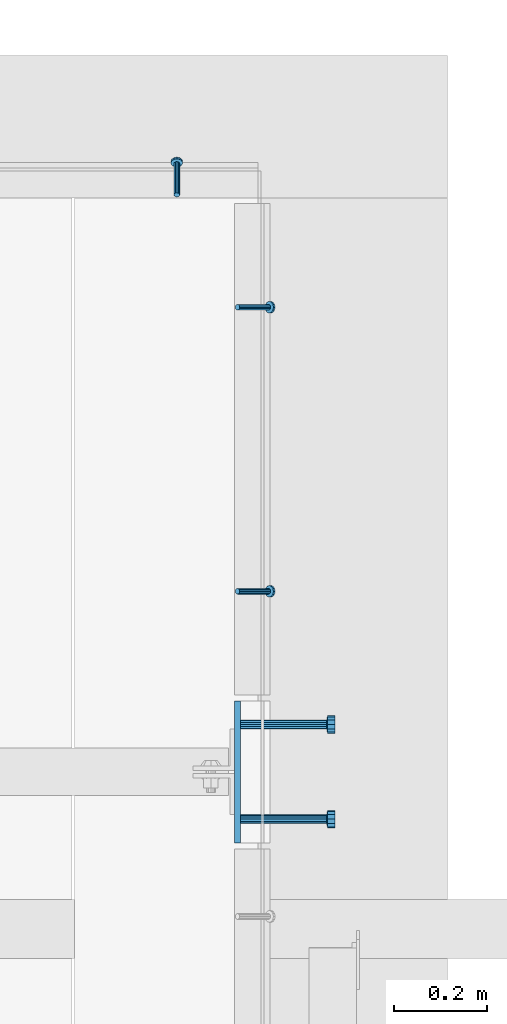
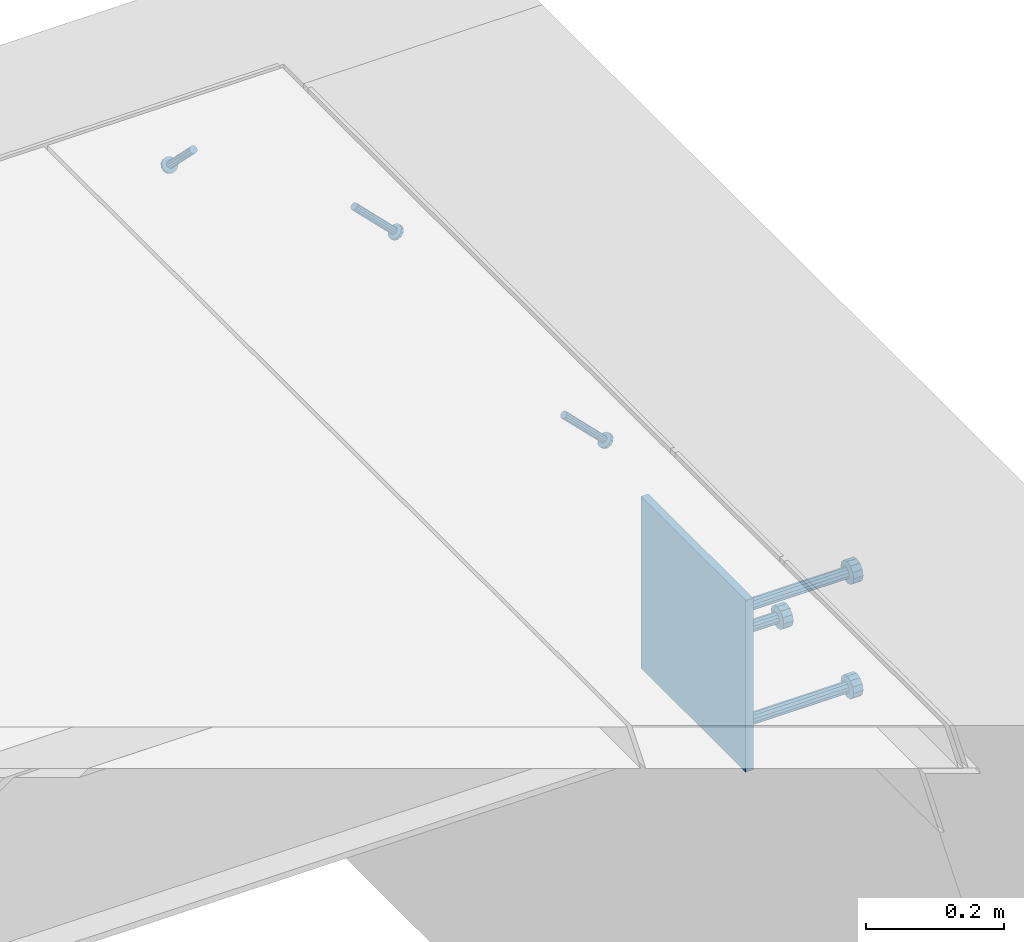
# One storey, part 2153 of 3843: 4 beams, 3 members, 3 elements without a shape of their own.
"""IFC2X3 building model written with IfcOpenShell, lengths in millimetres."""

from ifc_helpers import new_model, si_unit, frame, origin_with_axes, place, context, subcontext, project, spatial, faceted_brep, material, type_object, element, aggregate, save


model = new_model("IFC2X3")

# Units and contexts
model_context = context("Model", 3, precision=1e-05, world=origin_with_axes())
body_context = subcontext(model_context, "Body", "Model", "MODEL_VIEW")
ifc_project = project(units=[si_unit("LENGTHUNIT", "METRE", prefix="MILLI"), si_unit("AREAUNIT", "SQUARE_METRE"), si_unit("VOLUMEUNIT", "CUBIC_METRE"), si_unit("MASSUNIT", "GRAM", prefix="KILO"), si_unit("TIMEUNIT", "SECOND"), si_unit("PLANEANGLEUNIT", "RADIAN"), si_unit("SOLIDANGLEUNIT", "STERADIAN"), si_unit("THERMODYNAMICTEMPERATUREUNIT", "DEGREE_CELSIUS"), si_unit("LUMINOUSINTENSITYUNIT", "LUMEN")], contexts=[model_context])

# Site, building, storey
site_placement = place(None, origin_with_axes())
site = spatial("IfcSite", under=ifc_project, at=site_placement, CompositionType="ELEMENT")
building_placement = place(site_placement, origin_with_axes())
building = spatial("IfcBuilding", under=site, at=building_placement, Name="Undefined", CompositionType="ELEMENT")
storey_placement = place(building_placement, origin_with_axes())
storey = spatial("IfcBuildingStorey", under=building, at=storey_placement, Name="Undefined", CompositionType="ELEMENT", Elevation=0.0)

# Assembly, members
assembly_1_placement = place(storey_placement, origin_with_axes())
assembly_1 = element("IfcElementAssembly", 1, at=assembly_1_placement, inside=storey, Name="ANGLE", AssemblyPlace="NOTDEFINED", PredefinedType="RIGID_FRAME")
ifc_material_1 = material(Name="STEEL/A108")
member_type = type_object("IfcMemberType", PredefinedType="NOTDEFINED")
member_1_placement = place(assembly_1_placement, frame((65849.4999695419, 18456.2751644599, 30422.8500045777), z_axis=(0.0, 1.0, 0.0), x_axis=(0.707106781186548, 0.0, -0.707106781186548)))
member_1 = element("IfcMember", 2, at=member_1_placement, type_object=member_type, material=ifc_material_1, Name="HEADED STUD ANCHOR", context=body_context, shape_type="Brep", body=[
    faceted_brep([(7.27595761418343e-12, -3.18000006675175, 5.5), (0.0, -5.49999999998363, 3.1800000667572), (94.4879985803855, -5.50000000011278, 3.1800000667572), (94.4879985803782, -3.18000006687362, 5.5), (0.0, -6.3499999046162, 0.0), (94.4879985803855, -6.34999990474535, 0.0), (0.0, -5.49999999998363, -3.1800000667572), (94.4879985803855, -5.50000000011278, -3.1800000667572), (7.27595761418343e-12, -3.18000006675175, -5.5), (94.4879985803782, -3.18000006687362, -5.5), (7.27595761418343e-12, -1.81898940354586e-12, -6.34999990463257), (94.4879985803782, -1.20053300634027e-10, -6.34999990463257), (0.0, 3.18000006675175, -5.5), (94.4879985803709, 3.18000006663351, -5.5), (7.27595761418343e-12, 5.49999999998363, -3.1800000667572), (94.4879985803709, 5.49999999987267, -3.1800000667572), (7.27595761418343e-12, 6.3499999046162, 0.0), (94.4879985803673, 6.34999990450706, 0.0), (7.27595761418343e-12, 5.49999999998363, 3.1800000667572), (94.4879985803709, 5.49999999987267, 3.1800000667572), (0.0, 3.18000006675175, 5.5), (94.4879985803709, 3.18000006663351, 5.5), (7.27595761418343e-12, -1.81898940354586e-12, 6.34999990463257), (94.4879985803782, -1.20053300634027e-10, 6.34999990463257), (96.5199985498621, -10.9899997712273, 6.34999990463257), (96.5199985498548, -6.34000015270249, 10.9899997711182), (96.5199985498621, -12.6999998093743, 0.0), (96.5199985498621, -10.9899997712273, -6.34999990463257), (96.5199985498548, -6.34000015270249, -10.9899997711182), (96.5199985498475, -1.21872290037572e-10, -12.6899995803833), (96.5199985498402, 6.34000015245874, -10.9899997711182), (96.519998549833, 10.9899997709817, -6.34999990463257), (96.519998549833, 12.6999998091305, 0.0), (96.519998549833, 10.9899997709817, 6.34999990463257), (96.5199985498402, 6.34000015245874, 10.9899997711182), (96.5199985498475, -1.21872290037572e-10, 12.6899995803833), (101.599998473539, -10.9899997712328, 6.34999990463257), (101.599998473532, -6.34000015270976, 10.9899997711182), (101.599998473539, -12.6999998093797, 0.0), (101.599998473539, -10.9899997712328, -6.34999990463257), (101.599998473532, -6.34000015270976, -10.9899997711182), (101.599998473524, -1.29148247651756e-10, -12.6899995803833), (101.599998473517, 6.34000015245329, -10.9899997711182), (101.59999847351, 10.9899997709763, -6.34999990463257), (101.599998473503, 12.6999998091196, 0.0), (101.59999847351, 10.9899997709763, 6.34999990463257), (101.599998473517, 6.34000015245329, 10.9899997711182), (101.599998473524, -1.29148247651756e-10, 12.6899995803833)], [[[0, 1, 2, 3]], [[1, 4, 5, 2]], [[4, 6, 7, 5]], [[6, 8, 9, 7]], [[8, 10, 11, 9]], [[10, 12, 13, 11]], [[12, 14, 15, 13]], [[14, 16, 17, 15]], [[16, 18, 19, 17]], [[18, 20, 21, 19]], [[20, 22, 23, 21]], [[22, 0, 3, 23]], [[22, 20, 18, 16, 14, 12, 10, 8, 6, 4, 1, 0]], [[3, 2, 24, 25]], [[2, 5, 26, 24]], [[5, 7, 27, 26]], [[7, 9, 28, 27]], [[9, 11, 29, 28]], [[11, 13, 30, 29]], [[13, 15, 31, 30]], [[15, 17, 32, 31]], [[17, 19, 33, 32]], [[19, 21, 34, 33]], [[21, 23, 35, 34]], [[23, 3, 25, 35]], [[25, 24, 36, 37]], [[24, 26, 38, 36]], [[26, 27, 39, 38]], [[27, 28, 40, 39]], [[28, 29, 41, 40]], [[29, 30, 42, 41]], [[30, 31, 43, 42]], [[31, 32, 44, 43]], [[32, 33, 45, 44]], [[33, 34, 46, 45]], [[34, 35, 47, 46]], [[35, 25, 37, 47]], [[38, 39, 40, 41, 42, 43, 44, 45, 46, 47, 37, 36]]]),
])
member_2_placement = place(assembly_1_placement, frame((65849.4999695419, 17846.6751644599, 30422.8500045777), z_axis=(0.0, 1.0, 0.0), x_axis=(0.707106781186548, 0.0, -0.707106781186548)))
member_2 = element("IfcMember", 3, at=member_2_placement, type_object=member_type, material=ifc_material_1, Name="HEADED STUD ANCHOR", context=body_context, shape_type="Brep", body=[
    faceted_brep([(7.27595761418343e-12, -3.18000006675175, 5.5), (0.0, -5.49999999998363, 3.1800000667572), (94.4879985803855, -5.50000000011278, 3.1800000667572), (94.4879985803782, -3.18000006687362, 5.5), (0.0, -6.3499999046162, 0.0), (94.4879985803855, -6.34999990474535, 0.0), (0.0, -5.49999999998363, -3.1800000667572), (94.4879985803855, -5.50000000011278, -3.1800000667572), (7.27595761418343e-12, -3.18000006675175, -5.5), (94.4879985803782, -3.18000006687362, -5.5), (7.27595761418343e-12, -1.81898940354586e-12, -6.34999990463257), (94.4879985803782, -1.20053300634027e-10, -6.34999990463257), (0.0, 3.18000006675175, -5.5), (94.4879985803709, 3.18000006663351, -5.5), (7.27595761418343e-12, 5.49999999998363, -3.1800000667572), (94.4879985803709, 5.49999999987267, -3.1800000667572), (7.27595761418343e-12, 6.3499999046162, 0.0), (94.4879985803673, 6.34999990450706, 0.0), (7.27595761418343e-12, 5.49999999998363, 3.1800000667572), (94.4879985803709, 5.49999999987267, 3.1800000667572), (0.0, 3.18000006675175, 5.5), (94.4879985803709, 3.18000006663351, 5.5), (7.27595761418343e-12, -1.81898940354586e-12, 6.34999990463257), (94.4879985803782, -1.20053300634027e-10, 6.34999990463257), (96.5199985498621, -10.9899997712273, 6.34999990463257), (96.5199985498548, -6.34000015270249, 10.9899997711182), (96.5199985498621, -12.6999998093743, 0.0), (96.5199985498621, -10.9899997712273, -6.34999990463257), (96.5199985498548, -6.34000015270249, -10.9899997711182), (96.5199985498475, -1.21872290037572e-10, -12.6899995803833), (96.5199985498402, 6.34000015245874, -10.9899997711182), (96.519998549833, 10.9899997709817, -6.34999990463257), (96.519998549833, 12.6999998091305, 0.0), (96.519998549833, 10.9899997709817, 6.34999990463257), (96.5199985498402, 6.34000015245874, 10.9899997711182), (96.5199985498475, -1.21872290037572e-10, 12.6899995803833), (101.599998473539, -10.9899997712328, 6.34999990463257), (101.599998473532, -6.34000015270976, 10.9899997711182), (101.599998473539, -12.6999998093797, 0.0), (101.599998473539, -10.9899997712328, -6.34999990463257), (101.599998473532, -6.34000015270976, -10.9899997711182), (101.599998473524, -1.29148247651756e-10, -12.6899995803833), (101.599998473517, 6.34000015245329, -10.9899997711182), (101.59999847351, 10.9899997709763, -6.34999990463257), (101.599998473503, 12.6999998091196, 0.0), (101.59999847351, 10.9899997709763, 6.34999990463257), (101.599998473517, 6.34000015245329, 10.9899997711182), (101.599998473524, -1.29148247651756e-10, 12.6899995803833)], [[[0, 1, 2, 3]], [[1, 4, 5, 2]], [[4, 6, 7, 5]], [[6, 8, 9, 7]], [[8, 10, 11, 9]], [[10, 12, 13, 11]], [[12, 14, 15, 13]], [[14, 16, 17, 15]], [[16, 18, 19, 17]], [[18, 20, 21, 19]], [[20, 22, 23, 21]], [[22, 0, 3, 23]], [[22, 20, 18, 16, 14, 12, 10, 8, 6, 4, 1, 0]], [[3, 2, 24, 25]], [[2, 5, 26, 24]], [[5, 7, 27, 26]], [[7, 9, 28, 27]], [[9, 11, 29, 28]], [[11, 13, 30, 29]], [[13, 15, 31, 30]], [[15, 17, 32, 31]], [[17, 19, 33, 32]], [[19, 21, 34, 33]], [[21, 23, 35, 34]], [[23, 3, 25, 35]], [[25, 24, 36, 37]], [[24, 26, 38, 36]], [[26, 27, 39, 38]], [[27, 28, 40, 39]], [[28, 29, 41, 40]], [[29, 30, 42, 41]], [[30, 31, 43, 42]], [[31, 32, 44, 43]], [[32, 33, 45, 44]], [[33, 34, 46, 45]], [[34, 35, 47, 46]], [[35, 25, 37, 47]], [[38, 39, 40, 41, 42, 43, 44, 45, 46, 47, 37, 36]]]),
])
aggregate(assembly_1, [member_1, member_2])

# Assembly, member
assembly_2_placement = place(storey_placement, origin_with_axes())
assembly_2 = element("IfcElementAssembly", 4, at=assembly_2_placement, inside=storey, Name="ANGLE", AssemblyPlace="NOTDEFINED", PredefinedType="RIGID_FRAME")
member_3_placement = place(assembly_2_placement, frame((65719.3243549701, 18697.5749969422, 30422.8500030518), z_axis=(-1.0, 0.0, 0.0), x_axis=(5.70000238222118e-08, 0.707106781186546, -0.707106781186546)))
member_3 = element("IfcMember", 5, at=member_3_placement, type_object=member_type, material=ifc_material_1, Name="HEADED STUD ANCHOR", context=body_context, shape_type="Brep", body=[
    faceted_brep([(7.27595761418343e-12, -3.18000006675175, 5.5), (0.0, -5.49999999998363, 3.1800000667572), (94.4879985803855, -5.50000000011278, 3.1800000667572), (94.4879985803782, -3.18000006687362, 5.5), (0.0, -6.3499999046162, 0.0), (94.4879985803855, -6.34999990474535, 0.0), (0.0, -5.49999999998363, -3.1800000667572), (94.4879985803855, -5.50000000011278, -3.1800000667572), (7.27595761418343e-12, -3.18000006675175, -5.5), (94.4879985803782, -3.18000006687362, -5.5), (7.27595761418343e-12, -1.81898940354586e-12, -6.34999990463257), (94.4879985803782, -1.20053300634027e-10, -6.34999990463257), (0.0, 3.18000006675175, -5.5), (94.4879985803709, 3.18000006663351, -5.5), (7.27595761418343e-12, 5.49999999998363, -3.1800000667572), (94.4879985803709, 5.49999999987267, -3.1800000667572), (7.27595761418343e-12, 6.3499999046162, 0.0), (94.4879985803673, 6.34999990450706, 0.0), (7.27595761418343e-12, 5.49999999998363, 3.1800000667572), (94.4879985803709, 5.49999999987267, 3.1800000667572), (0.0, 3.18000006675175, 5.5), (94.4879985803709, 3.18000006663351, 5.5), (7.27595761418343e-12, -1.81898940354586e-12, 6.34999990463257), (94.4879985803782, -1.20053300634027e-10, 6.34999990463257), (96.5199985498621, -10.9899997712273, 6.34999990463257), (96.5199985498548, -6.34000015270249, 10.9899997711182), (96.5199985498621, -12.6999998093743, 0.0), (96.5199985498621, -10.9899997712273, -6.34999990463257), (96.5199985498548, -6.34000015270249, -10.9899997711182), (96.5199985498475, -1.21872290037572e-10, -12.6899995803833), (96.5199985498402, 6.34000015245874, -10.9899997711182), (96.519998549833, 10.9899997709817, -6.34999990463257), (96.519998549833, 12.6999998091305, 0.0), (96.519998549833, 10.9899997709817, 6.34999990463257), (96.5199985498402, 6.34000015245874, 10.9899997711182), (96.5199985498475, -1.21872290037572e-10, 12.6899995803833), (101.599998473539, -10.9899997712328, 6.34999990463257), (101.599998473532, -6.34000015270976, 10.9899997711182), (101.599998473539, -12.6999998093797, 0.0), (101.599998473539, -10.9899997712328, -6.34999990463257), (101.599998473532, -6.34000015270976, -10.9899997711182), (101.599998473524, -1.29148247651756e-10, -12.6899995803833), (101.599998473517, 6.34000015245329, -10.9899997711182), (101.59999847351, 10.9899997709763, -6.34999990463257), (101.599998473503, 12.6999998091196, 0.0), (101.59999847351, 10.9899997709763, 6.34999990463257), (101.599998473517, 6.34000015245329, 10.9899997711182), (101.599998473524, -1.29148247651756e-10, 12.6899995803833)], [[[0, 1, 2, 3]], [[1, 4, 5, 2]], [[4, 6, 7, 5]], [[6, 8, 9, 7]], [[8, 10, 11, 9]], [[10, 12, 13, 11]], [[12, 14, 15, 13]], [[14, 16, 17, 15]], [[16, 18, 19, 17]], [[18, 20, 21, 19]], [[20, 22, 23, 21]], [[22, 0, 3, 23]], [[22, 20, 18, 16, 14, 12, 10, 8, 6, 4, 1, 0]], [[3, 2, 24, 25]], [[2, 5, 26, 24]], [[5, 7, 27, 26]], [[7, 9, 28, 27]], [[9, 11, 29, 28]], [[11, 13, 30, 29]], [[13, 15, 31, 30]], [[15, 17, 32, 31]], [[17, 19, 33, 32]], [[19, 21, 34, 33]], [[21, 23, 35, 34]], [[23, 3, 25, 35]], [[25, 24, 36, 37]], [[24, 26, 38, 36]], [[26, 27, 39, 38]], [[27, 28, 40, 39]], [[28, 29, 41, 40]], [[29, 30, 42, 41]], [[30, 31, 43, 42]], [[31, 32, 44, 43]], [[32, 33, 45, 44]], [[33, 34, 46, 45]], [[34, 35, 47, 46]], [[35, 25, 37, 47]], [[38, 39, 40, 41, 42, 43, 44, 45, 46, 47, 37, 36]]]),
])
aggregate(assembly_2, [member_3])

# Assembly, beams
assembly_3_placement = place(storey_placement, origin_with_axes())
assembly_3 = element("IfcElementAssembly", 6, at=assembly_3_placement, inside=storey, Name="EMBED PLATE", AssemblyPlace="NOTDEFINED", PredefinedType="RIGID_FRAME")
ifc_material_2 = material(Name="STEEL/A36")
beam_type_1 = type_object("IfcBeamType", PredefinedType="NOTDEFINED")
beam_1_placement = place(assembly_3_placement, frame((65849.4999969482, 17459.325, 30422.85), z_axis=(0.0, -1.0, 0.0), x_axis=(0.0, 0.0, -1.0)))
beam_1 = element("IfcBeam", 7, at=beam_1_placement, type_object=beam_type_1, material=ifc_material_2, Name="EMBED PLATE", context=body_context, shape_type="Brep", body=[
    faceted_brep([(-1.0550138540566e-10, 6.34999999999854, -152.400000000664), (1.0550138540566e-10, 6.34999999999854, 152.400000000656), (304.799999999999, 6.34999999999854, 152.400000000001), (304.799999999999, 6.34999999999854, -152.400000000001), (1.0550138540566e-10, -6.34999999999854, 152.400000000656), (304.799999999999, -6.34999999999854, 152.400000000001), (-1.0550138540566e-10, -6.34999999999854, -152.400000000664), (304.799999999999, -6.34999999999854, -152.400000000001)], [[[0, 1, 2, 3]], [[1, 4, 5, 2]], [[4, 6, 7, 5]], [[6, 0, 3, 7]], [[5, 7, 3, 2]], [[6, 4, 1, 0]]]),
])
beam_type_2 = type_object("IfcBeamType", PredefinedType="NOTDEFINED")
beam_2_placement = place(assembly_3_placement, frame((65855.8499969482, 17560.925, 30168.85), z_axis=(0.0, 1.0, 0.0), x_axis=(1.0, 0.0, 0.0)))
beam_2 = element("IfcBeam", 8, at=beam_2_placement, type_object=beam_type_2, material=ifc_material_1, Name="HEADED STUD ANCHOR", context=body_context, shape_type="Brep", body=[
    faceted_brep([(0.0, -9.52000045776367, 0.0), (0.0, -8.25, -4.76000022888184), (184.912000000004, -8.25, -4.76000022888184), (184.912000000004, -9.52000045776367, 0.0), (0.0, -4.76000022888184, -8.25), (184.912000000004, -4.76000022888184, -8.25), (0.0, 0.0, -9.52000045776367), (184.912000000004, 0.0, -9.52000045776367), (0.0, 4.76000022888184, -8.25), (184.912000000004, 4.76000022888184, -8.25), (0.0, 8.25, -4.76000022888184), (184.912000000004, 8.25, -4.76000022888184), (0.0, 9.52000045776367, 0.0), (184.912000000004, 9.52000045776367, 0.0), (0.0, 8.25, 4.76000022888184), (184.912000000004, 8.25, 4.76000022888184), (0.0, 4.76000022888184, 8.25), (184.912000000004, 4.76000022888184, 8.25), (0.0, 0.0, 9.52000045776367), (184.912000000004, 0.0, 9.52000045776367), (0.0, -4.76000022888184, 8.25), (184.912000000004, -4.76000022888184, 8.25), (0.0, -8.25, 4.76000022888184), (184.912000000004, -8.25, 4.76000022888184), (186.944000000003, -16.5, -9.52000045776367), (186.944000000003, -19.0499992370605, 0.0), (186.944000000003, -9.52000045776367, -16.5), (186.944000000003, 0.0, -19.0499992370605), (186.944000000003, 9.52000045776367, -16.5), (186.944000000003, 16.5, -9.52000045776367), (186.944000000003, 19.0499992370605, 0.0), (186.944000000003, 16.5, 9.52000045776367), (186.944000000003, 9.52000045776367, 16.5), (186.944000000003, 0.0, 19.0499992370605), (186.944000000003, -9.52000045776367, 16.5), (186.944000000003, -16.5, 9.52000045776367), (203.199999999997, -16.5, -9.52000045776367), (203.199999999997, -19.0499992370605, 0.0), (203.199999999997, -9.52000045776367, -16.5), (203.199999999997, 0.0, -19.0499992370605), (203.199999999997, 9.52000045776367, -16.5), (203.199999999997, 16.5, -9.52000045776367), (203.199999999997, 19.0499992370605, 0.0), (203.199999999997, 16.5, 9.52000045776367), (203.199999999997, 9.52000045776367, 16.5), (203.199999999997, 0.0, 19.0499992370605), (203.199999999997, -9.52000045776367, 16.5), (203.199999999997, -16.5, 9.52000045776367)], [[[0, 1, 2, 3]], [[1, 4, 5, 2]], [[4, 6, 7, 5]], [[6, 8, 9, 7]], [[8, 10, 11, 9]], [[10, 12, 13, 11]], [[12, 14, 15, 13]], [[14, 16, 17, 15]], [[16, 18, 19, 17]], [[18, 20, 21, 19]], [[20, 22, 23, 21]], [[22, 0, 3, 23]], [[22, 20, 18, 16, 14, 12, 10, 8, 6, 4, 1, 0]], [[3, 2, 24, 25]], [[2, 5, 26, 24]], [[5, 7, 27, 26]], [[7, 9, 28, 27]], [[9, 11, 29, 28]], [[11, 13, 30, 29]], [[13, 15, 31, 30]], [[15, 17, 32, 31]], [[17, 19, 33, 32]], [[19, 21, 34, 33]], [[21, 23, 35, 34]], [[23, 3, 25, 35]], [[25, 24, 36, 37]], [[24, 26, 38, 36]], [[26, 27, 39, 38]], [[27, 28, 40, 39]], [[28, 29, 41, 40]], [[29, 30, 42, 41]], [[30, 31, 43, 42]], [[31, 32, 44, 43]], [[32, 33, 45, 44]], [[33, 34, 46, 45]], [[34, 35, 47, 46]], [[35, 25, 37, 47]], [[38, 39, 40, 41, 42, 43, 44, 45, 46, 47, 37, 36]]]),
])
beam_3_placement = place(assembly_3_placement, frame((65855.8499969482, 17357.725, 30372.05), z_axis=(0.0, 1.0, 0.0), x_axis=(1.0, 0.0, 0.0)))
beam_3 = element("IfcBeam", 9, at=beam_3_placement, type_object=beam_type_2, material=ifc_material_2, Name="PLATE", context=body_context, shape_type="Brep", body=[
    faceted_brep([(0.0, -9.52000045776367, 0.0), (0.0, -8.25, -4.76000022888184), (184.912000000004, -8.25, -4.76000022888184), (184.912000000004, -9.52000045776367, 0.0), (0.0, -4.76000022888184, -8.25), (184.912000000004, -4.76000022888184, -8.25), (0.0, 0.0, -9.52000045776367), (184.912000000004, 0.0, -9.52000045776367), (0.0, 4.76000022888184, -8.25), (184.912000000004, 4.76000022888184, -8.25), (0.0, 8.25, -4.76000022888184), (184.912000000004, 8.25, -4.76000022888184), (0.0, 9.52000045776367, 0.0), (184.912000000004, 9.52000045776367, 0.0), (0.0, 8.25, 4.76000022888184), (184.912000000004, 8.25, 4.76000022888184), (0.0, 4.76000022888184, 8.25), (184.912000000004, 4.76000022888184, 8.25), (0.0, 0.0, 9.52000045776367), (184.912000000004, 0.0, 9.52000045776367), (0.0, -4.76000022888184, 8.25), (184.912000000004, -4.76000022888184, 8.25), (0.0, -8.25, 4.76000022888184), (184.912000000004, -8.25, 4.76000022888184), (186.944000000003, -16.5, -9.52000045776367), (186.944000000003, -19.0499992370605, 0.0), (186.944000000003, -9.52000045776367, -16.5), (186.944000000003, 0.0, -19.0499992370605), (186.944000000003, 9.52000045776367, -16.5), (186.944000000003, 16.5, -9.52000045776367), (186.944000000003, 19.0499992370605, 0.0), (186.944000000003, 16.5, 9.52000045776367), (186.944000000003, 9.52000045776367, 16.5), (186.944000000003, 0.0, 19.0499992370605), (186.944000000003, -9.52000045776367, 16.5), (186.944000000003, -16.5, 9.52000045776367), (203.199999999997, -16.5, -9.52000045776367), (203.199999999997, -19.0499992370605, 0.0), (203.199999999997, -9.52000045776367, -16.5), (203.199999999997, 0.0, -19.0499992370605), (203.199999999997, 9.52000045776367, -16.5), (203.199999999997, 16.5, -9.52000045776367), (203.199999999997, 19.0499992370605, 0.0), (203.199999999997, 16.5, 9.52000045776367), (203.199999999997, 9.52000045776367, 16.5), (203.199999999997, 0.0, 19.0499992370605), (203.199999999997, -9.52000045776367, 16.5), (203.199999999997, -16.5, 9.52000045776367)], [[[0, 1, 2, 3]], [[1, 4, 5, 2]], [[4, 6, 7, 5]], [[6, 8, 9, 7]], [[8, 10, 11, 9]], [[10, 12, 13, 11]], [[12, 14, 15, 13]], [[14, 16, 17, 15]], [[16, 18, 19, 17]], [[18, 20, 21, 19]], [[20, 22, 23, 21]], [[22, 0, 3, 23]], [[22, 20, 18, 16, 14, 12, 10, 8, 6, 4, 1, 0]], [[3, 2, 24, 25]], [[2, 5, 26, 24]], [[5, 7, 27, 26]], [[7, 9, 28, 27]], [[9, 11, 29, 28]], [[11, 13, 30, 29]], [[13, 15, 31, 30]], [[15, 17, 32, 31]], [[17, 19, 33, 32]], [[19, 21, 34, 33]], [[21, 23, 35, 34]], [[23, 3, 25, 35]], [[25, 24, 36, 37]], [[24, 26, 38, 36]], [[26, 27, 39, 38]], [[27, 28, 40, 39]], [[28, 29, 41, 40]], [[29, 30, 42, 41]], [[30, 31, 43, 42]], [[31, 32, 44, 43]], [[32, 33, 45, 44]], [[33, 34, 46, 45]], [[34, 35, 47, 46]], [[35, 25, 37, 47]], [[38, 39, 40, 41, 42, 43, 44, 45, 46, 47, 37, 36]]]),
])
beam_4_placement = place(assembly_3_placement, frame((65855.8499969482, 17357.725, 30168.85), z_axis=(0.0, 1.0, 0.0), x_axis=(1.0, 0.0, 0.0)))
beam_4 = element("IfcBeam", 10, at=beam_4_placement, type_object=beam_type_2, material=ifc_material_1, Name="HEADED STUD ANCHOR", context=body_context, shape_type="Brep", body=[
    faceted_brep([(0.0, -9.52000045776367, 0.0), (0.0, -8.25, -4.76000022888184), (184.912000000004, -8.25, -4.76000022888184), (184.912000000004, -9.52000045776367, 0.0), (0.0, -4.76000022888184, -8.25), (184.912000000004, -4.76000022888184, -8.25), (0.0, 0.0, -9.52000045776367), (184.912000000004, 0.0, -9.52000045776367), (0.0, 4.76000022888184, -8.25), (184.912000000004, 4.76000022888184, -8.25), (0.0, 8.25, -4.76000022888184), (184.912000000004, 8.25, -4.76000022888184), (0.0, 9.52000045776367, 0.0), (184.912000000004, 9.52000045776367, 0.0), (0.0, 8.25, 4.76000022888184), (184.912000000004, 8.25, 4.76000022888184), (0.0, 4.76000022888184, 8.25), (184.912000000004, 4.76000022888184, 8.25), (0.0, 0.0, 9.52000045776367), (184.912000000004, 0.0, 9.52000045776367), (0.0, -4.76000022888184, 8.25), (184.912000000004, -4.76000022888184, 8.25), (0.0, -8.25, 4.76000022888184), (184.912000000004, -8.25, 4.76000022888184), (186.944000000003, -16.5, -9.52000045776367), (186.944000000003, -19.0499992370605, 0.0), (186.944000000003, -9.52000045776367, -16.5), (186.944000000003, 0.0, -19.0499992370605), (186.944000000003, 9.52000045776367, -16.5), (186.944000000003, 16.5, -9.52000045776367), (186.944000000003, 19.0499992370605, 0.0), (186.944000000003, 16.5, 9.52000045776367), (186.944000000003, 9.52000045776367, 16.5), (186.944000000003, 0.0, 19.0499992370605), (186.944000000003, -9.52000045776367, 16.5), (186.944000000003, -16.5, 9.52000045776367), (203.199999999997, -16.5, -9.52000045776367), (203.199999999997, -19.0499992370605, 0.0), (203.199999999997, -9.52000045776367, -16.5), (203.199999999997, 0.0, -19.0499992370605), (203.199999999997, 9.52000045776367, -16.5), (203.199999999997, 16.5, -9.52000045776367), (203.199999999997, 19.0499992370605, 0.0), (203.199999999997, 16.5, 9.52000045776367), (203.199999999997, 9.52000045776367, 16.5), (203.199999999997, 0.0, 19.0499992370605), (203.199999999997, -9.52000045776367, 16.5), (203.199999999997, -16.5, 9.52000045776367)], [[[0, 1, 2, 3]], [[1, 4, 5, 2]], [[4, 6, 7, 5]], [[6, 8, 9, 7]], [[8, 10, 11, 9]], [[10, 12, 13, 11]], [[12, 14, 15, 13]], [[14, 16, 17, 15]], [[16, 18, 19, 17]], [[18, 20, 21, 19]], [[20, 22, 23, 21]], [[22, 0, 3, 23]], [[22, 20, 18, 16, 14, 12, 10, 8, 6, 4, 1, 0]], [[3, 2, 24, 25]], [[2, 5, 26, 24]], [[5, 7, 27, 26]], [[7, 9, 28, 27]], [[9, 11, 29, 28]], [[11, 13, 30, 29]], [[13, 15, 31, 30]], [[15, 17, 32, 31]], [[17, 19, 33, 32]], [[19, 21, 34, 33]], [[21, 23, 35, 34]], [[23, 3, 25, 35]], [[25, 24, 36, 37]], [[24, 26, 38, 36]], [[26, 27, 39, 38]], [[27, 28, 40, 39]], [[28, 29, 41, 40]], [[29, 30, 42, 41]], [[30, 31, 43, 42]], [[31, 32, 44, 43]], [[32, 33, 45, 44]], [[33, 34, 46, 45]], [[34, 35, 47, 46]], [[35, 25, 37, 47]], [[38, 39, 40, 41, 42, 43, 44, 45, 46, 47, 37, 36]]]),
])
aggregate(assembly_3, [beam_2, beam_3, beam_4, beam_1])

save(model, "model.ifc")
